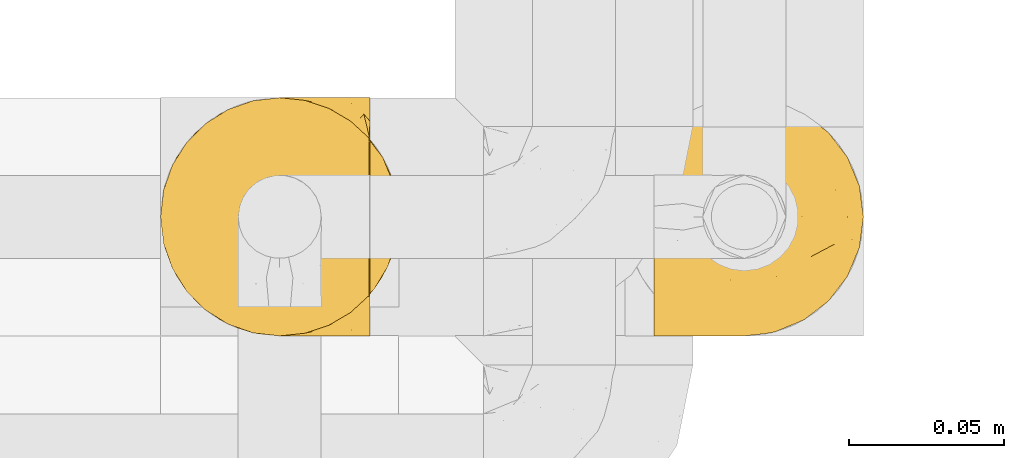
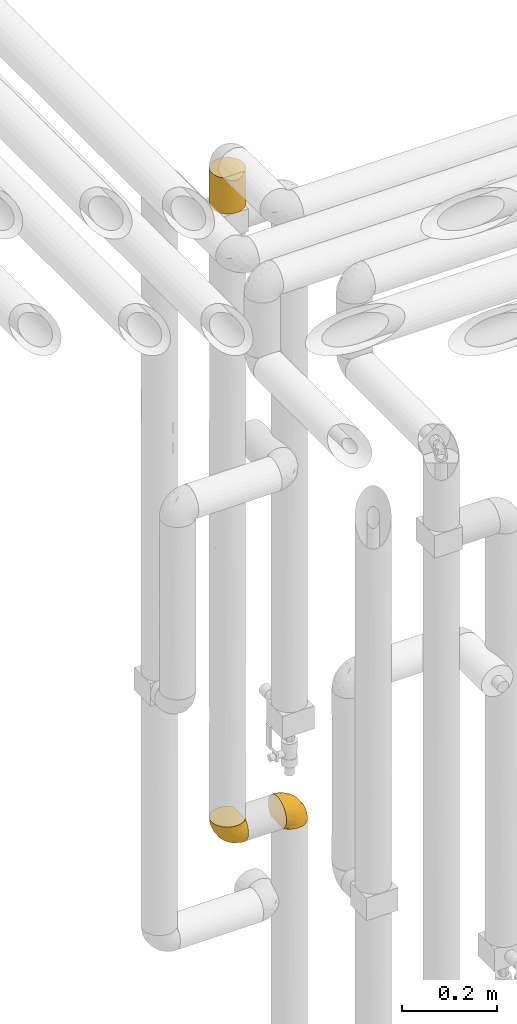
# One storey, part 292 of 827: 3 coverings.
"""IFC2X3 building model written with IfcOpenShell, lengths in millimetres."""

import ifcopenshell
import ifcopenshell.guid

model = None  # the IFC model being written
_history = None  # IfcOwnerHistory: only IFC2X3 demands one
_inside = {}  # id of a spatial element -> (the spatial element, [elements in it])
_under = {}  # id of a project, library or spatial element -> (it, [spatial elements below it])
_declared = {}  # id of a project -> (the project, [libraries it declares])
_typed = {}  # id of a type object -> (the type object, [elements of that type])
_made_of = {}  # id of a material, layer set ... -> (it, [elements and type objects made of it])


def new_model(schema):
    """Start an empty IFC model of exactly this schema.

    Asked for "IFC4X3", IfcOpenShell would pick the latest addendum, in which some entities
    have other attributes; the version numbers below select the first issue.
    IFC2X3 requires an IfcOwnerHistory on every rooted entity: one is made here for all.
    """
    global model, _history
    if schema == "IFC4X3":
        model = ifcopenshell.file(schema_version=(4, 3, 0, 0))
    else:
        model = ifcopenshell.file(schema=schema)
    _inside.clear()
    _under.clear()
    _declared.clear()
    _typed.clear()
    _made_of.clear()
    _history = None
    if model.schema == "IFC2X3":
        org = make("IfcOrganization", Name="unknown")
        user = make(
            "IfcPersonAndOrganization",
            ThePerson=make("IfcPerson", FamilyName="unknown"),
            TheOrganization=org,
        )
        app = make(
            "IfcApplication",
            ApplicationDeveloper=org,
            Version="unknown",
            ApplicationFullName="unknown",
            ApplicationIdentifier="unknown",
        )
        _history = make(
            "IfcOwnerHistory",
            OwningUser=user,
            OwningApplication=app,
            ChangeAction="ADDED",
            CreationDate=0,
        )
    return model


def make(cls, **values):
    """One entity of the class cls with the attributes given. An attribute that is None is left unset."""
    return model.create_entity(
        cls, **{name: value for name, value in values.items() if value is not None}
    )


def entity(cls, *values):
    """Any entity or typed value of the class cls, its attributes in the order of the schema. None: left unset."""
    e = model.create_entity(cls)
    for i, value in enumerate(values):
        if value is not None:
            e[i] = value
    return e


def rooted(cls, **values):
    """An entity with a GlobalId (a new one), such as an element, a storey or a relation."""
    return make(cls, GlobalId=ifcopenshell.guid.new(), OwnerHistory=_history, **values)


def si_unit(unit_type, name, prefix=None):
    """IfcSIUnit, for example si_unit("LENGTHUNIT", "METRE", prefix="MILLI")."""
    return make("IfcSIUnit", UnitType=unit_type, Prefix=prefix, Name=name)


def converted_unit(unit_type, name, factor, base, dimensions=None, offset=None):
    """IfcConversionBasedUnit, such as the inch: factor (a typed value) times the base unit."""
    return make(
        "IfcConversionBasedUnit"
        if offset is None
        else "IfcConversionBasedUnitWithOffset",
        ConversionOffset=offset,
        Dimensions=None
        if dimensions is None
        else entity("IfcDimensionalExponents", *dimensions),
        UnitType=unit_type,
        Name=name,
        ConversionFactor=make(
            "IfcMeasureWithUnit", ValueComponent=factor, UnitComponent=base
        ),
    )


def derived_unit(unit_type, elements):
    """IfcDerivedUnit: a product of units, each with its exponent."""
    return make(
        "IfcDerivedUnit",
        Elements=[
            make("IfcDerivedUnitElement", Unit=unit, Exponent=power)
            for unit, power in elements
        ],
        UnitType=unit_type,
    )


def assignment(units):
    """IfcUnitAssignment: the units of a project."""
    return None if units is None else make("IfcUnitAssignment", Units=units)


def point(xyz):
    """IfcCartesianPoint."""
    return None if xyz is None else make("IfcCartesianPoint", Coordinates=xyz)


def direction(xyz):
    """IfcDirection."""
    return None if xyz is None else make("IfcDirection", DirectionRatios=xyz)


def frame(location, z_axis=None, x_axis=None):
    """IfcAxis2Placement3D, a coordinate frame: its origin and axes. An axis left out is left unset."""
    return make(
        "IfcAxis2Placement3D",
        Location=point(location),
        Axis=direction(z_axis),
        RefDirection=direction(x_axis),
    )


def origin():
    """The frame at (0, 0, 0) with its axes left unset."""
    return frame((0.0, 0.0, 0.0))


def place(relative_to, where):
    """IfcLocalPlacement: puts the frame where relative to a parent placement (None: the world)."""
    return make(
        "IfcLocalPlacement", PlacementRelTo=relative_to, RelativePlacement=where
    )


def context(
    kind, dimensions, precision=None, world=None, true_north=None, identifier=None
):
    """IfcGeometricRepresentationContext, for example the 3D "Model" context."""
    return make(
        "IfcGeometricRepresentationContext",
        ContextIdentifier=identifier,
        ContextType=kind,
        CoordinateSpaceDimension=dimensions,
        Precision=precision,
        WorldCoordinateSystem=world,
        TrueNorth=true_north,
    )


def subcontext(parent, identifier, kind, view, scale=None):
    """IfcGeometricRepresentationSubContext, for example "Body" below "Model"."""
    return make(
        "IfcGeometricRepresentationSubContext",
        ContextIdentifier=identifier,
        ContextType=kind,
        ParentContext=parent,
        TargetScale=scale,
        TargetView=view,
    )


def project(units=None, contexts=None):
    """IfcProject with its units and contexts."""
    return rooted(
        "IfcProject",
        Name="project",
        RepresentationContexts=contexts,
        UnitsInContext=assignment(units),
    )


def spatial(cls, under=None, at=None, **own):
    """A site, building, storey or space (cls), placed at a placement, below another one or the project."""
    s = rooted(cls, ObjectPlacement=at, **own)
    if under is not None:
        _under.setdefault(under.id(), (under, []))[1].append(s)
    return s


def faces_of(points, faces, orient=None, outer=None):
    """IfcFace entities. A face is a list of loops; a loop is a list of indices into points, from 0.

    orient and outer hold one flag for each loop. By default every Orientation is true, the
    first loop of a face is its IfcFaceOuterBound and the others are IfcFaceBound.
    """
    made = []
    for i, loops in enumerate(faces):
        bounds = []
        for j, loop in enumerate(loops):
            is_outer = j == 0 if outer is None else outer[i][j]
            bounds.append(
                make(
                    "IfcFaceOuterBound" if is_outer else "IfcFaceBound",
                    Bound=make("IfcPolyLoop", Polygon=[points[k] for k in loop]),
                    Orientation=True if orient is None else orient[i][j],
                )
            )
        made.append(make("IfcFace", Bounds=bounds))
    return made


def faceted_brep(points, faces, orient=None, outer=None, voids=None):
    """IfcFacetedBrep: a solid bounded by flat faces; with voids (closed shells), ...WithVoids."""
    shared = [point(p) for p in points]
    hull = make("IfcClosedShell", CfsFaces=faces_of(shared, faces, orient, outer))
    if voids is None:
        return make("IfcFacetedBrep", Outer=hull)
    return make(
        "IfcFacetedBrepWithVoids",
        Outer=hull,
        Voids=[
            make(cls, CfsFaces=faces_of(shared, fs, o, b)) for cls, fs, o, b in voids
        ],
    )


def shape(context_of_items, identifier, shape_type, items):
    """IfcShapeRepresentation: the items that make up one representation, for example the "Body"."""
    return make(
        "IfcShapeRepresentation",
        ContextOfItems=context_of_items,
        RepresentationIdentifier=identifier,
        RepresentationType=shape_type,
        Items=items,
    )


def made_of(thing, what):
    """Note that an element or type object is made of a material, layer set ...; save() writes the relation."""
    if what is not None:
        _made_of.setdefault(what.id(), (what, []))[1].append(thing)
    return thing


def element(
    cls,
    number,
    at=None,
    inside=None,
    cuts=None,
    type_object=None,
    material=None,
    context=None,
    identifier="Body",
    shape_type=None,
    held_by="IfcProductDefinitionShape",
    body=None,
    shapes=None,
    **own,
):
    """One element of the class cls, such as IfcWall. Its Tag is "e" and its number.

    at: its placement. inside: the storey or other place that contains it. cuts: it is an
    opening in that element (IfcRelVoidsElement). A single representation is given by context,
    identifier, shape_type and body (its items); several are given by shapes. held_by: the class
    of the entity that holds the representations. save() writes the other relations.
    """
    e = rooted(cls, Tag="e%d" % number, ObjectPlacement=at, **own)
    if body is not None:
        shapes = [shape(context, identifier, shape_type, body)]
    if shapes is not None:
        e.Representation = make(held_by, Representations=shapes)
    if inside is not None:
        _inside.setdefault(inside.id(), (inside, []))[1].append(e)
    if cuts is not None:
        rooted(
            "IfcRelVoidsElement", RelatingBuildingElement=cuts, RelatedOpeningElement=e
        )
    if type_object is not None:
        _typed.setdefault(type_object.id(), (type_object, []))[1].append(e)
    return made_of(e, material)


def aggregate(whole, parts):
    """IfcRelAggregates: a whole, such as a stair, and the parts it consists of."""
    return rooted("IfcRelAggregates", RelatingObject=whole, RelatedObjects=parts)


def save(model, path):
    """Write the relations noted so far, then the file.

    IfcRelAggregates (storeys below a building ...), IfcRelContainedInSpatialStructure (elements
    in a storey), IfcRelDefinesByType, IfcRelAssociatesMaterial and IfcRelDeclares: one each for
    every whole, place, type object, material and project.
    """
    for whole, parts in _under.values():
        aggregate(whole, parts)
    for where, things in _inside.values():
        rooted(
            "IfcRelContainedInSpatialStructure",
            RelatedElements=things,
            RelatingStructure=where,
        )
    for kind, things in _typed.values():
        rooted("IfcRelDefinesByType", RelatedObjects=things, RelatingType=kind)
    for what, things in _made_of.values():
        rooted("IfcRelAssociatesMaterial", RelatedObjects=things, RelatingMaterial=what)
    for by, libraries in _declared.values():
        rooted("IfcRelDeclares", RelatingContext=by, RelatedDefinitions=libraries)
    model.write(path)


model = new_model("IFC2X3")

# Units and contexts
model_context = context("Model", 3, precision=0.01, world=origin(), true_north=direction((6.12303176911189e-17, 1.0)))
body_context = subcontext(model_context, "Body", "Model", "MODEL_VIEW")
ifc_project = project(units=[si_unit("LENGTHUNIT", "METRE", prefix="MILLI"), si_unit("AREAUNIT", "SQUARE_METRE"), si_unit("VOLUMEUNIT", "CUBIC_METRE"), converted_unit("PLANEANGLEUNIT", "DEGREE", entity("IfcRatioMeasure", 0.0174532925199433), si_unit("PLANEANGLEUNIT", "RADIAN"), dimensions=[0, 0, 0, 0, 0, 0, 0]), si_unit("MASSUNIT", "GRAM", prefix="KILO"), derived_unit("MASSDENSITYUNIT", [(si_unit("MASSUNIT", "GRAM", prefix="KILO"), 1), (si_unit("LENGTHUNIT", "METRE"), -3)]), derived_unit("MOMENTOFINERTIAUNIT", [(si_unit("LENGTHUNIT", "METRE"), 4)]), si_unit("TIMEUNIT", "SECOND"), si_unit("FREQUENCYUNIT", "HERTZ"), si_unit("THERMODYNAMICTEMPERATUREUNIT", "DEGREE_CELSIUS"), derived_unit("THERMALTRANSMITTANCEUNIT", [(si_unit("MASSUNIT", "GRAM", prefix="KILO"), 1), (si_unit("THERMODYNAMICTEMPERATUREUNIT", "KELVIN"), -1), (si_unit("TIMEUNIT", "SECOND"), -3)]), derived_unit("VOLUMETRICFLOWRATEUNIT", [(si_unit("LENGTHUNIT", "METRE"), 3), (si_unit("TIMEUNIT", "SECOND"), -1)]), derived_unit("MASSFLOWRATEUNIT", [(si_unit("MASSUNIT", "GRAM", prefix="KILO"), 1), (si_unit("TIMEUNIT", "SECOND"), -1)]), derived_unit("ROTATIONALFREQUENCYUNIT", [(si_unit("TIMEUNIT", "SECOND"), -1)]), si_unit("ELECTRICCURRENTUNIT", "AMPERE"), si_unit("ELECTRICVOLTAGEUNIT", "VOLT"), si_unit("POWERUNIT", "WATT"), si_unit("FORCEUNIT", "NEWTON", prefix="KILO"), si_unit("ILLUMINANCEUNIT", "LUX"), si_unit("LUMINOUSFLUXUNIT", "LUMEN"), si_unit("LUMINOUSINTENSITYUNIT", "CANDELA"), derived_unit("USERDEFINED", [(si_unit("MASSUNIT", "GRAM", prefix="KILO"), -1), (si_unit("LENGTHUNIT", "METRE"), -2), (si_unit("TIMEUNIT", "SECOND"), 3), (si_unit("LUMINOUSFLUXUNIT", "LUMEN"), 1)]), derived_unit("LINEARVELOCITYUNIT", [(si_unit("LENGTHUNIT", "METRE"), 1), (si_unit("TIMEUNIT", "SECOND"), -1)]), si_unit("PRESSUREUNIT", "PASCAL"), derived_unit("USERDEFINED", [(si_unit("LENGTHUNIT", "METRE"), -2), (si_unit("MASSUNIT", "GRAM", prefix="KILO"), 1), (si_unit("TIMEUNIT", "SECOND"), -2)]), derived_unit("LINEARFORCEUNIT", [(si_unit("MASSUNIT", "GRAM", prefix="KILO"), 1), (si_unit("LENGTHUNIT", "METRE"), 1), (si_unit("TIMEUNIT", "SECOND"), -2), (si_unit("LENGTHUNIT", "METRE"), -1)]), derived_unit("PLANARFORCEUNIT", [(si_unit("MASSUNIT", "GRAM", prefix="KILO"), 1), (si_unit("LENGTHUNIT", "METRE"), 1), (si_unit("TIMEUNIT", "SECOND"), -2), (si_unit("LENGTHUNIT", "METRE"), -2)])], contexts=[model_context])

# Site, building, storey
site_placement = place(None, origin())
site = spatial("IfcSite", under=ifc_project, at=site_placement, CompositionType="ELEMENT")
building_placement = place(site_placement, origin())
building = spatial("IfcBuilding", under=site, at=building_placement, CompositionType="ELEMENT")
storey_placement = place(building_placement, frame((0.0, 0.0, 28200.0)))
storey = spatial("IfcBuildingStorey", under=building, at=storey_placement, Name="08", CompositionType="ELEMENT", Elevation=28200.0)

# Coverings
covering_1_placement = place(storey_placement, frame((35112.19, 15782.0, 1249.3)))
element("IfcCovering", 1, at=covering_1_placement, inside=storey, Name=":ADSK_", ObjectType=":ADSK_", PredefinedType="INSULATION", context=body_context, shape_type="Brep", body=[
    faceted_brep([(1.6, 5.41, 47.38), (1.6, 9.99, 54.67), (1.6, 16.08, 60.76), (1.6, 23.37, 65.34), (1.6, 31.49, 68.18), (1.6, 40.05, 69.15), (1.6, 48.61, 68.18), (1.6, 56.73, 65.33), (1.6, 64.02, 60.75), (1.6, 70.11, 54.66), (1.6, 74.69, 47.37), (1.6, 77.53, 39.25), (1.6, 78.5, 30.7), (1.6, 77.63, 22.59), (1.6, 75.08, 14.86), (1.6, 70.97, 7.84), (1.6, 65.47, 1.85), (1.6, 63.27, 1.85), (1.6, 61.53, 1.85), (1.6, 59.57, 1.85), (1.6, 57.6, 1.85), (1.6, 55.63, 1.85), (1.6, 53.67, 1.85), (1.6, 51.7, 1.85), (1.6, 49.73, 1.85), (1.6, 47.54, 1.85), (1.6, 45.34, 1.85), (1.6, 43.15, 1.85), (1.6, 40.96, 1.85), (1.6, 38.76, 1.85), (1.6, 36.57, 1.85), (1.6, 34.37, 1.85), (1.6, 32.18, 1.85), (1.6, 29.98, 1.85), (1.6, 27.79, 1.85), (1.6, 25.6, 1.85), (1.6, 23.4, 1.85), (1.6, 21.21, 1.85), (1.6, 19.01, 1.85), (1.6, 16.82, 1.85), (1.6, 14.62, 1.85), (1.6, 9.12, 7.85), (1.6, 5.0, 14.88), (1.6, 2.46, 22.61), (1.6, 1.6, 30.7), (1.6, 2.56, 39.26), (1.85, 65.47, 1.6), (7.85, 70.97, 1.6), (14.87, 75.09, 1.6), (22.6, 77.63, 1.6), (30.7, 78.5, 1.6), (40.65, 77.19, 1.6), (49.92, 73.34, 1.6), (57.88, 67.23, 1.6), (63.99, 59.27, 1.6), (67.84, 50.0, 1.6), (69.15, 40.05, 1.6), (67.84, 30.09, 1.6), (63.99, 20.82, 1.6), (57.88, 12.86, 1.6), (49.92, 6.75, 1.6), (40.65, 2.91, 1.6), (30.7, 1.6, 1.6), (22.6, 2.46, 1.6), (14.87, 5.0, 1.6), (7.85, 9.12, 1.6), (1.85, 14.62, 1.6), (1.85, 16.82, 1.6), (1.85, 17.8, 1.6), (1.85, 19.39, 1.6), (1.85, 20.98, 1.6), (1.85, 22.57, 1.6), (1.85, 24.16, 1.6), (1.85, 25.75, 1.6), (1.85, 27.33, 1.6), (1.85, 28.92, 1.6), (1.85, 30.51, 1.6), (1.85, 32.1, 1.6), (1.85, 33.69, 1.6), (1.85, 35.28, 1.6), (1.85, 36.87, 1.6), (1.85, 38.46, 1.6), (1.85, 40.05, 1.6), (1.85, 41.63, 1.6), (1.85, 43.22, 1.6), (1.85, 44.81, 1.6), (1.85, 46.4, 1.6), (1.85, 47.99, 1.6), (1.85, 49.58, 1.6), (1.85, 51.17, 1.6), (1.85, 52.76, 1.6), (1.85, 54.72, 1.6), (1.85, 56.69, 1.6), (1.85, 58.88, 1.6), (1.85, 61.08, 1.6), (1.85, 63.27, 1.6), (1.77, 37.77, 1.78), (1.78, 36.07, 1.77), (1.77, 32.96, 1.78), (1.77, 31.36, 1.77), (1.76, 56.52, 1.79), (1.77, 54.96, 1.78), (1.79, 18.75, 1.76), (1.78, 58.07, 1.77), (1.78, 50.37, 1.77), (1.78, 23.36, 1.76), (1.78, 24.95, 1.77), (1.78, 42.43, 1.77), (1.74, 15.97, 1.8), (1.78, 51.96, 1.76), (1.78, 53.47, 1.77), (1.77, 48.63, 1.78), (1.78, 63.93, 1.77), (1.78, 40.93, 1.77), (1.78, 29.72, 1.76), (1.77, 62.4, 1.77), (1.77, 60.92, 1.78), (1.77, 17.31, 1.77), (1.78, 21.74, 1.77), (1.78, 34.56, 1.77), (1.77, 20.18, 1.78), (1.77, 14.62, 1.77), (1.72, 14.62, 1.8), (1.66, 14.62, 1.82), (1.77, 65.47, 1.77), (1.8, 65.47, 1.72), (1.82, 65.47, 1.66), (1.79, 59.5, 1.76), (1.78, 47.1, 1.77), (1.79, 45.61, 1.76), (1.78, 28.18, 1.77), (1.82, 14.62, 1.66), (1.8, 14.62, 1.72), (1.76, 26.61, 1.78), (1.66, 65.47, 1.82), (1.72, 65.47, 1.8), (1.78, 39.32, 1.77), (1.77, 44.12, 1.78), (9.41, 72.26, 3.72), (17.65, 76.57, 7.41), (7.41, 71.77, 6.13), (21.47, 78.5, 21.47), (15.21, 77.9, 19.34), (16.15, 78.5, 26.8), (28.75, 78.5, 8.87), (13.67, 75.52, 9.2), (12.79, 76.13, 12.79), (19.18, 77.81, 14.62), (29.16, 78.5, 7.34), (9.04, 72.4, 5.33), (7.41, 76.56, 17.64), (5.74, 71.77, 7.7), (3.72, 72.25, 9.41), (8.87, 78.5, 28.75), (26.8, 78.5, 16.15), (9.53, 75.75, 14.14), (7.34, 78.5, 29.16), (37.63, 50.46, 57.02), (17.92, 52.75, 64.92), (27.45, 40.05, 64.0), (37.01, 77.7, 11.92), (34.22, 77.66, 19.16), (45.87, 71.02, 28.65), (56.57, 63.45, 24.62), (52.31, 70.55, 15.19), (42.07, 75.57, 18.36), (44.74, 75.57, 9.2), (21.49, 72.61, 46.98), (11.02, 72.61, 50.24), (15.64, 67.24, 56.1), (26.02, 77.74, 28.97), (36.59, 57.43, 54.46), (65.49, 47.19, 21.34), (63.99, 54.76, 18.4), (15.2, 40.05, 66.44), (60.27, 63.45, 12.07), (45.25, 60.1, 45.49), (35.21, 63.72, 50.57), (22.52, 76.83, 36.04), (12.03, 76.34, 42.07), (13.32, 60.51, 62.12), (35.9, 72.59, 37.37), (33.87, 76.05, 29.39), (25.73, 66.15, 53.59), (26.34, 60.51, 58.06), (46.78, 51.88, 49.27), (59.54, 55.34, 29.63), (60.18, 48.67, 33.21), (53.93, 53.89, 40.1), (53.36, 46.73, 44.08), (49.36, 40.05, 49.36), (38.4, 40.05, 56.68), (66.44, 40.05, 15.2), (50.09, 63.95, 35.57), (41.08, 67.24, 41.7), (31.14, 69.62, 46.4), (28.19, 73.6, 41.41), (64.0, 40.05, 27.45), (56.68, 40.05, 38.4), (43.9, 4.52, 12.99), (65.46, 32.72, 21.33), (52.22, 27.18, 42.89), (37.61, 29.63, 57.04), (15.64, 12.86, 56.11), (13.31, 19.59, 62.13), (50.02, 9.54, 21.89), (59.28, 16.64, 16.62), (53.05, 17.48, 32.9), (21.48, 7.49, 46.99), (11.01, 7.49, 50.25), (12.03, 3.75, 42.08), (41.02, 20.75, 49.91), (35.39, 2.33, 15.6), (26.8, 1.6, 16.15), (28.75, 1.6, 8.87), (7.34, 1.6, 29.16), (65.81, 26.94, 13.16), (53.28, 9.54, 10.83), (59.8, 31.21, 33.8), (61.82, 25.33, 25.02), (17.91, 27.35, 64.92), (41.4, 8.17, 32.83), (40.48, 4.3, 20.56), (26.34, 19.59, 58.07), (31.68, 2.23, 21.46), (27.68, 2.45, 28.1), (16.15, 1.6, 26.8), (21.47, 1.6, 21.47), (28.05, 12.86, 51.29), (22.54, 3.27, 36.04), (8.87, 1.6, 28.75), (37.3, 2.29, 8.45), (41.07, 12.86, 41.73), (32.24, 6.89, 39.27), (47.4, 12.43, 33.56), (35.77, 4.1, 27.29), (17.65, 3.53, 7.41), (11.06, 6.88, 3.51), (8.55, 8.16, 4.68), (6.63, 9.02, 5.52), (12.77, 5.0, 8.75), (12.79, 3.96, 12.79), (7.41, 3.52, 17.65), (18.97, 2.4, 13.9), (3.72, 7.83, 9.42), (5.76, 8.32, 7.68), (15.21, 2.19, 19.33), (9.52, 4.34, 14.13)], [[[0, 1, 2, 3, 4, 5, 6, 7, 8, 9, 10, 11, 12, 13, 14, 15, 16, 17, 18, 19, 20, 21, 22, 23, 24, 25, 26, 27, 28, 29, 30, 31, 32, 33, 34, 35, 36, 37, 38, 39, 40, 41, 42, 43, 44, 45]], [[46, 47, 48, 49, 50, 51, 52, 53, 54, 55, 56, 57, 58, 59, 60, 61, 62, 63, 64, 65, 66, 67, 68, 69, 70, 71, 72, 73, 74, 75, 76, 77, 78, 79, 80, 81, 82, 83, 84, 85, 86, 87, 88, 89, 90, 91, 92, 93, 94, 95]], [[96, 97, 30]], [[98, 77, 99]], [[100, 101, 21]], [[69, 68, 102]], [[20, 19, 103]], [[24, 23, 104]], [[20, 103, 100]], [[72, 105, 106]], [[84, 83, 107]], [[89, 88, 104]], [[108, 67, 66]], [[109, 110, 90]], [[111, 25, 24]], [[112, 17, 16]], [[82, 113, 83]], [[109, 23, 22]], [[114, 76, 75]], [[105, 36, 106]], [[104, 111, 24]], [[18, 115, 116]], [[97, 96, 80]], [[67, 108, 117]], [[105, 71, 118]], [[31, 97, 119]], [[102, 120, 69]], [[108, 121, 122, 123, 40]], [[112, 95, 115]], [[17, 115, 18]], [[94, 116, 115]], [[117, 68, 67]], [[38, 117, 39]], [[112, 124, 125, 126, 46]], [[17, 112, 115]], [[70, 120, 118]], [[39, 117, 108]], [[120, 38, 37]], [[120, 37, 118]], [[120, 70, 69]], [[116, 94, 127]], [[128, 86, 129]], [[117, 38, 102]], [[74, 130, 75]], [[99, 33, 32]], [[115, 95, 94]], [[39, 108, 40]], [[108, 66, 131, 132, 121]], [[105, 72, 71]], [[118, 37, 36]], [[71, 70, 118]], [[35, 106, 36]], [[36, 105, 118]], [[35, 133, 106]], [[74, 73, 133]], [[106, 133, 73]], [[99, 114, 33]], [[133, 35, 34]], [[73, 72, 106]], [[95, 112, 46]], [[112, 16, 134, 135, 124]], [[130, 114, 75]], [[99, 76, 114]], [[114, 130, 33]], [[34, 33, 130]], [[78, 77, 98]], [[98, 119, 78]], [[130, 133, 34]], [[133, 130, 74]], [[79, 97, 80]], [[98, 99, 32]], [[98, 32, 31]], [[77, 76, 99]], [[97, 79, 119]], [[136, 96, 29]], [[30, 97, 31]], [[136, 29, 28]], [[81, 80, 96]], [[29, 96, 30]], [[31, 119, 98]], [[119, 79, 78]], [[96, 136, 81]], [[82, 81, 136]], [[113, 107, 83]], [[84, 107, 137]], [[107, 27, 137]], [[113, 28, 107]], [[27, 107, 28]], [[85, 84, 137]], [[137, 27, 26]], [[113, 136, 28]], [[136, 113, 82]], [[109, 89, 104]], [[86, 85, 129]], [[89, 109, 90]], [[111, 87, 128]], [[26, 129, 137]], [[88, 111, 104]], [[25, 111, 128]], [[22, 110, 109]], [[23, 109, 104]], [[110, 91, 90]], [[100, 92, 101]], [[110, 22, 101]], [[91, 110, 101]], [[116, 19, 18]], [[111, 88, 87]], [[127, 103, 19]], [[25, 128, 26]], [[86, 128, 87]], [[128, 129, 26]], [[137, 129, 85]], [[120, 102, 38]], [[117, 102, 68]], [[91, 101, 92]], [[21, 101, 22]], [[93, 92, 103]], [[100, 21, 20]], [[100, 103, 92]], [[127, 93, 103]], [[93, 127, 94]], [[116, 127, 19]], [[126, 138, 47]], [[48, 138, 139]], [[140, 125, 124]], [[141, 142, 143]], [[144, 49, 139]], [[145, 140, 146]], [[48, 139, 49]], [[139, 145, 147]], [[49, 144, 148, 50]], [[126, 125, 149]], [[14, 13, 150]], [[151, 146, 140]], [[149, 140, 145]], [[152, 151, 135]], [[152, 14, 150]], [[16, 15, 134]], [[13, 153, 150]], [[124, 151, 140]], [[141, 147, 142]], [[14, 152, 15]], [[15, 152, 134]], [[47, 46, 126]], [[139, 154, 144]], [[138, 48, 47]], [[125, 140, 149]], [[135, 134, 152]], [[146, 155, 142]], [[145, 146, 147]], [[149, 139, 138]], [[147, 141, 154]], [[147, 146, 142]], [[139, 147, 154]], [[139, 149, 145]], [[149, 138, 126]], [[155, 146, 151]], [[150, 143, 142]], [[152, 155, 151]], [[150, 142, 155]], [[13, 12, 156, 153]], [[153, 143, 150]], [[152, 150, 155]], [[151, 124, 135]], [[157, 158, 159]], [[160, 154, 161]], [[162, 163, 164]], [[165, 166, 160]], [[167, 168, 169]], [[141, 170, 161]], [[156, 12, 11]], [[158, 157, 171]], [[172, 55, 173]], [[158, 6, 174]], [[175, 54, 53]], [[52, 166, 164]], [[52, 164, 53]], [[54, 175, 173]], [[166, 52, 51]], [[176, 177, 171]], [[178, 143, 179]], [[156, 11, 179]], [[8, 7, 180]], [[169, 9, 8]], [[179, 143, 153, 156]], [[179, 11, 10]], [[168, 179, 10]], [[181, 162, 182]], [[179, 167, 178]], [[183, 184, 177]], [[183, 169, 184]], [[176, 171, 185]], [[172, 186, 187]], [[158, 7, 6]], [[159, 158, 174]], [[184, 180, 158]], [[54, 173, 55]], [[180, 169, 8]], [[188, 189, 187]], [[9, 168, 10]], [[186, 188, 187]], [[190, 157, 159, 191]], [[55, 172, 192]], [[176, 193, 194]], [[161, 170, 182]], [[162, 164, 165]], [[175, 164, 163]], [[51, 50, 148]], [[167, 195, 196]], [[178, 182, 170]], [[6, 5, 174]], [[158, 180, 7]], [[169, 180, 184]], [[169, 168, 9]], [[179, 168, 167]], [[182, 162, 165]], [[162, 194, 193]], [[161, 165, 160]], [[195, 181, 196]], [[192, 172, 197]], [[192, 56, 55]], [[189, 190, 198]], [[198, 197, 187]], [[172, 187, 197]], [[185, 189, 188]], [[198, 187, 189]], [[186, 172, 173]], [[173, 163, 186]], [[193, 186, 163]], [[176, 185, 188]], [[185, 157, 190]], [[188, 186, 193]], [[177, 176, 194]], [[188, 193, 176]], [[162, 193, 163]], [[195, 177, 194]], [[171, 177, 184]], [[181, 195, 194]], [[183, 167, 169]], [[162, 181, 194]], [[196, 182, 178]], [[158, 171, 184]], [[171, 157, 185]], [[177, 195, 183]], [[167, 183, 195]], [[182, 196, 181]], [[178, 170, 143]], [[178, 167, 196]], [[164, 175, 53]], [[173, 175, 163]], [[160, 51, 148]], [[164, 166, 165]], [[51, 160, 166]], [[160, 148, 144, 154]], [[141, 161, 154]], [[182, 165, 161]], [[190, 189, 185]], [[143, 170, 141]], [[60, 199, 61]], [[197, 200, 192]], [[201, 190, 202]], [[200, 57, 192]], [[203, 204, 2]], [[205, 206, 207]], [[208, 209, 210]], [[211, 207, 201]], [[212, 213, 214]], [[45, 215, 210]], [[216, 206, 58]], [[45, 44, 215]], [[59, 217, 60]], [[60, 217, 199]], [[0, 45, 210]], [[218, 201, 219]], [[202, 159, 220]], [[205, 221, 222]], [[223, 204, 203]], [[1, 203, 2]], [[57, 200, 216]], [[220, 3, 204]], [[220, 174, 4]], [[1, 0, 209]], [[212, 224, 213]], [[225, 226, 227]], [[228, 223, 203]], [[208, 210, 229]], [[210, 226, 229]], [[3, 220, 4]], [[58, 206, 59]], [[209, 203, 1]], [[202, 220, 223]], [[228, 203, 208]], [[202, 211, 201]], [[3, 2, 204]], [[202, 190, 191, 159]], [[210, 215, 230, 226]], [[199, 212, 231]], [[232, 233, 221]], [[233, 208, 229]], [[207, 206, 219]], [[217, 206, 205]], [[227, 224, 225]], [[233, 232, 228]], [[201, 207, 219]], [[234, 232, 221]], [[218, 219, 200]], [[202, 223, 211]], [[174, 220, 159]], [[174, 5, 4]], [[61, 231, 62]], [[220, 204, 223]], [[210, 209, 0]], [[203, 209, 208]], [[225, 233, 229]], [[224, 227, 213]], [[221, 233, 235]], [[57, 56, 192]], [[198, 218, 197]], [[200, 219, 216]], [[201, 198, 190]], [[197, 218, 200]], [[198, 201, 218]], [[206, 216, 219]], [[58, 57, 216]], [[231, 212, 214]], [[222, 212, 199]], [[228, 211, 223]], [[207, 211, 232]], [[62, 231, 214]], [[199, 231, 61]], [[233, 228, 208]], [[211, 228, 232]], [[222, 221, 235]], [[234, 205, 207]], [[206, 217, 59]], [[199, 217, 205]], [[205, 222, 199]], [[224, 222, 235]], [[222, 224, 212]], [[224, 235, 225]], [[233, 225, 235]], [[226, 225, 229]], [[205, 234, 221]], [[207, 232, 234]], [[63, 214, 236]], [[214, 213, 236]], [[214, 63, 62]], [[237, 236, 238]], [[238, 132, 131]], [[236, 237, 64]], [[239, 240, 241]], [[63, 236, 64]], [[131, 66, 65]], [[237, 131, 65]], [[242, 230, 43]], [[237, 65, 64]], [[239, 121, 132]], [[42, 242, 43]], [[241, 240, 243]], [[41, 123, 244]], [[43, 230, 215, 44]], [[244, 122, 245]], [[227, 246, 243]], [[241, 247, 245]], [[121, 239, 245]], [[41, 40, 123]], [[132, 238, 239]], [[244, 42, 41]], [[131, 237, 238]], [[240, 239, 238]], [[245, 239, 241]], [[247, 241, 246]], [[247, 244, 245]], [[238, 236, 240]], [[243, 236, 213]], [[236, 243, 240]], [[227, 226, 246]], [[243, 213, 227]], [[242, 246, 226]], [[243, 246, 241]], [[246, 242, 247]], [[244, 247, 242]], [[242, 226, 230]], [[42, 244, 242]], [[122, 244, 123]], [[122, 121, 245]]]),
])
covering_2_placement = place(storey_placement, frame((34952.89, 15782.05, 2877.4)))
element("IfcCovering", 2, at=covering_2_placement, inside=storey, Name=":ADSK_", ObjectType=":ADSK_", PredefinedType="INSULATION", context=body_context, shape_type="Brep", body=[
    faceted_brep([(6.74, 20.8, 1.6), (2.9, 30.06, 1.6), (1.6, 40.0, 1.6), (2.9, 49.93, 1.6), (6.74, 59.2, 1.6), (12.84, 67.15, 1.6), (20.8, 73.25, 1.6), (30.06, 77.09, 1.6), (40.0, 78.4, 1.6), (48.16, 77.52, 1.6), (55.94, 74.93, 1.6), (62.99, 70.75, 1.6), (69.0, 65.17, 1.6), (69.0, 14.82, 1.6), (62.99, 9.24, 1.6), (55.94, 5.06, 1.6), (48.16, 2.47, 1.6), (40.0, 1.6, 1.6), (30.06, 2.9, 1.6), (20.8, 6.74, 1.6), (12.84, 12.84, 1.6), (1.6, 40.0, 93.5), (2.48, 31.79, 93.5), (5.09, 23.98, 93.5), (9.31, 16.91, 93.5), (14.94, 10.9, 93.5), (65.05, 10.9, 93.5), (70.68, 16.91, 93.5), (74.9, 23.98, 93.5), (77.51, 31.79, 93.5), (78.4, 40.0, 93.5), (77.09, 49.93, 93.5), (73.25, 59.2, 93.5), (67.15, 67.15, 93.5), (59.2, 73.25, 93.5), (49.93, 77.09, 93.5), (40.0, 78.4, 93.5), (30.06, 77.09, 93.5), (20.8, 73.25, 93.5), (12.84, 67.15, 93.5), (6.74, 59.2, 93.5), (2.9, 49.93, 93.5), (77.78, 33.17, 10.38), (73.01, 20.38, 5.61), (75.97, 26.56, 8.57), (78.4, 40.0, 11.0), (59.51, 6.92, 89.52), (53.36, 4.0, 86.6), (46.78, 2.2, 84.8), (40.0, 1.6, 84.2), (33.21, 2.2, 84.8), (26.63, 4.0, 86.6), (20.48, 6.92, 89.52), (75.97, 53.43, 8.57), (77.78, 46.82, 10.38), (73.01, 59.61, 5.61)], [[[0, 1, 2, 3, 4, 5, 6, 7, 8, 9, 10, 11, 12, 13, 14, 15, 16, 17, 18, 19, 20]], [[21, 22, 23, 24, 25, 26, 27, 28, 29, 30, 31, 32, 33, 34, 35, 36, 37, 38, 39, 40, 41]], [[30, 29, 42]], [[28, 27, 43]], [[29, 28, 44]], [[42, 45, 30]], [[43, 44, 28]], [[13, 43, 27]], [[42, 29, 44]], [[27, 26, 13]], [[26, 46, 14]], [[47, 48, 16]], [[46, 47, 15]], [[14, 46, 15]], [[48, 17, 16]], [[16, 15, 47]], [[17, 48, 49]], [[26, 14, 13]], [[50, 51, 18]], [[52, 25, 19]], [[51, 52, 19]], [[49, 50, 17]], [[17, 50, 18]], [[51, 19, 18]], [[25, 20, 19]], [[0, 24, 23]], [[1, 23, 22]], [[2, 22, 21]], [[20, 24, 0]], [[0, 23, 1]], [[22, 2, 1]], [[24, 20, 25]], [[3, 2, 21, 41]], [[4, 3, 41, 40]], [[40, 39, 5, 4]], [[7, 6, 38, 37]], [[8, 7, 37, 36]], [[39, 38, 6, 5]], [[9, 36, 35]], [[10, 35, 34]], [[11, 34, 33]], [[8, 36, 9]], [[9, 35, 10]], [[34, 11, 10]], [[33, 12, 11]], [[53, 32, 31]], [[31, 30, 54]], [[45, 54, 30]], [[55, 12, 32]], [[54, 53, 31]], [[55, 32, 53]], [[32, 12, 33]], [[12, 55, 53, 54, 45, 42, 44, 43, 13]], [[52, 51, 50, 49, 48, 47, 46, 26, 25]]]),
])
covering_3_placement = place(storey_placement, frame((34952.84, 15782.0, 1239.95)))
element("IfcCovering", 3, at=covering_3_placement, inside=storey, Name=":ADSK_", ObjectType=":ADSK_", PredefinedType="INSULATION", context=body_context, shape_type="Brep", body=[
    faceted_brep([(23.36, 74.68, 69.15), (16.07, 70.1, 69.15), (9.98, 64.01, 69.15), (5.4, 56.72, 69.15), (2.56, 48.6, 69.15), (1.6, 40.05, 69.15), (2.56, 31.49, 69.15), (5.41, 23.36, 69.15), (9.99, 16.07, 69.15), (16.08, 9.98, 69.15), (23.37, 5.4, 69.15), (31.49, 2.56, 69.15), (40.05, 1.6, 69.15), (48.15, 2.46, 69.15), (55.88, 5.01, 69.15), (62.9, 9.13, 69.15), (68.89, 14.62, 69.15), (68.89, 16.82, 69.15), (68.89, 18.56, 69.15), (68.89, 20.52, 69.15), (68.89, 22.49, 69.15), (68.89, 24.46, 69.15), (68.89, 26.42, 69.15), (68.89, 28.39, 69.15), (68.89, 30.36, 69.15), (68.89, 32.55, 69.15), (68.89, 34.75, 69.15), (68.89, 36.94, 69.15), (68.89, 39.13, 69.15), (68.89, 41.33, 69.15), (68.89, 43.52, 69.15), (68.89, 45.72, 69.15), (68.89, 47.91, 69.15), (68.89, 50.11, 69.15), (68.89, 52.3, 69.15), (68.89, 54.49, 69.15), (68.89, 56.69, 69.15), (68.89, 58.88, 69.15), (68.89, 61.08, 69.15), (68.89, 63.27, 69.15), (68.89, 65.47, 69.15), (62.89, 70.97, 69.15), (55.86, 75.09, 69.15), (48.13, 77.64, 69.15), (40.05, 78.5, 69.15), (31.49, 77.53, 69.15), (69.15, 14.62, 68.89), (69.15, 9.12, 62.89), (69.15, 5.0, 55.87), (69.15, 2.46, 48.14), (69.15, 1.6, 40.05), (69.15, 2.91, 30.09), (69.15, 6.75, 20.82), (69.15, 12.86, 12.86), (69.15, 20.82, 6.75), (69.15, 30.09, 2.91), (69.15, 40.05, 1.6), (69.15, 50.0, 2.91), (69.15, 59.27, 6.75), (69.15, 67.23, 12.86), (69.15, 73.34, 20.82), (69.15, 77.19, 30.09), (69.15, 78.5, 40.05), (69.15, 77.63, 48.14), (69.15, 75.09, 55.87), (69.15, 70.97, 62.89), (69.15, 65.47, 68.89), (69.15, 63.27, 68.89), (69.15, 62.29, 68.89), (69.15, 60.7, 68.89), (69.15, 59.11, 68.89), (69.15, 57.52, 68.89), (69.15, 55.93, 68.89), (69.15, 54.34, 68.89), (69.15, 52.76, 68.89), (69.15, 51.17, 68.89), (69.15, 49.58, 68.89), (69.15, 47.99, 68.89), (69.15, 46.4, 68.89), (69.15, 44.81, 68.89), (69.15, 43.22, 68.89), (69.15, 41.63, 68.89), (69.15, 40.05, 68.89), (69.15, 38.46, 68.89), (69.15, 36.87, 68.89), (69.15, 35.28, 68.89), (69.15, 33.69, 68.89), (69.15, 32.1, 68.89), (69.15, 30.51, 68.89), (69.15, 28.92, 68.89), (69.15, 27.33, 68.89), (69.15, 25.37, 68.89), (69.15, 23.4, 68.89), (69.15, 21.21, 68.89), (69.15, 19.01, 68.89), (69.15, 16.82, 68.89), (68.96, 42.32, 68.97), (68.97, 44.02, 68.96), (68.97, 47.13, 68.97), (68.97, 48.74, 68.97), (68.95, 23.57, 68.98), (68.96, 25.13, 68.97), (68.98, 61.34, 68.96), (68.97, 22.02, 68.96), (68.97, 29.72, 68.96), (68.98, 56.73, 68.96), (68.97, 55.14, 68.96), (68.97, 37.66, 68.96), (68.94, 64.12, 69.0), (68.98, 28.13, 68.96), (68.98, 26.62, 68.96), (68.96, 31.46, 68.97), (68.97, 16.16, 68.96), (68.98, 39.16, 68.96), (68.98, 50.37, 68.96), (68.97, 17.69, 68.97), (68.96, 19.17, 68.97), (68.97, 62.78, 68.97), (68.97, 58.35, 68.96), (68.98, 45.53, 68.96), (68.96, 59.91, 68.97), (68.97, 65.47, 68.97), (68.94, 65.47, 69.02), (68.92, 65.47, 69.08), (68.97, 14.62, 68.97), (69.02, 14.62, 68.94), (69.08, 14.62, 68.92), (68.98, 20.59, 68.96), (68.97, 32.99, 68.96), (68.98, 34.48, 68.95), (68.97, 51.91, 68.96), (69.08, 65.47, 68.92), (69.02, 65.47, 68.94), (68.96, 53.48, 68.98), (68.92, 14.62, 69.08), (68.94, 14.62, 69.02), (68.97, 40.77, 68.96), (68.96, 35.97, 68.97), (67.02, 7.84, 61.33), (63.33, 3.53, 53.1), (64.61, 8.32, 63.33), (49.27, 1.6, 49.27), (51.4, 2.19, 55.53), (43.94, 1.6, 54.6), (61.87, 1.6, 41.99), (61.54, 4.57, 57.07), (57.95, 3.96, 57.95), (56.12, 2.28, 51.56), (63.4, 1.6, 41.58), (65.41, 7.69, 61.7), (53.1, 3.53, 63.33), (63.04, 8.32, 65.0), (61.33, 7.84, 67.02), (41.99, 1.6, 61.87), (54.6, 1.6, 43.94), (56.6, 4.34, 61.21), (41.58, 1.6, 63.4), (13.72, 29.63, 33.11), (5.82, 27.34, 52.82), (6.74, 40.05, 43.3), (58.82, 2.39, 33.73), (51.58, 2.43, 36.52), (42.09, 9.07, 24.87), (46.12, 16.64, 14.17), (55.56, 9.54, 18.43), (52.38, 4.52, 28.67), (61.54, 4.52, 26.0), (23.76, 7.49, 49.25), (20.5, 7.49, 59.72), (14.64, 12.85, 55.1), (41.77, 2.35, 44.72), (16.28, 22.66, 34.15), (49.4, 32.9, 5.25), (52.34, 25.33, 6.75), (4.3, 40.05, 55.54), (58.67, 16.64, 10.47), (25.26, 19.99, 25.49), (20.17, 16.37, 35.53), (34.7, 3.26, 48.22), (28.67, 3.75, 58.71), (8.62, 19.58, 57.42), (33.37, 7.5, 34.84), (41.35, 4.04, 36.87), (17.15, 13.94, 45.01), (12.68, 19.58, 44.4), (21.47, 28.21, 23.96), (41.11, 24.75, 11.2), (37.53, 31.42, 10.56), (30.64, 26.2, 16.81), (26.66, 33.36, 17.38), (21.38, 40.05, 21.38), (14.06, 40.05, 32.34), (55.54, 40.05, 4.3), (35.17, 16.14, 20.65), (29.04, 12.85, 29.66), (24.34, 10.47, 39.6), (29.33, 6.49, 42.55), (43.3, 40.05, 6.74), (32.34, 40.05, 14.06), (57.75, 75.57, 26.84), (49.41, 47.37, 5.28), (27.85, 52.91, 18.52), (13.7, 50.46, 33.13), (14.63, 67.23, 55.1), (8.61, 60.5, 57.43), (48.85, 70.55, 20.72), (54.13, 63.45, 11.46), (37.84, 62.61, 17.69), (23.75, 72.6, 49.26), (20.49, 72.6, 59.73), (28.66, 76.34, 58.71), (20.83, 59.34, 29.72), (55.15, 77.76, 35.35), (54.6, 78.5, 43.94), (61.87, 78.5, 41.99), (41.58, 78.5, 63.4), (57.58, 53.16, 4.93), (59.91, 70.55, 17.46), (36.94, 48.88, 10.94), (45.72, 54.76, 8.92), (5.82, 52.74, 52.83), (37.91, 71.93, 29.34), (50.18, 75.79, 30.26), (12.67, 60.5, 44.4), (49.29, 77.86, 39.06), (42.64, 77.64, 43.06), (43.94, 78.5, 54.6), (49.27, 78.5, 49.27), (19.45, 67.23, 42.69), (34.7, 76.82, 48.2), (41.99, 78.5, 61.87), (62.29, 77.8, 33.44), (29.01, 67.23, 29.67), (31.47, 73.2, 38.5), (37.18, 67.66, 23.35), (43.45, 75.99, 34.97), (63.33, 76.57, 53.1), (67.23, 73.21, 59.68), (66.07, 71.93, 62.19), (65.22, 71.07, 64.11), (61.99, 75.09, 57.97), (57.95, 76.13, 57.95), (53.09, 76.57, 63.33), (56.84, 77.69, 51.77), (61.33, 72.26, 67.02), (63.06, 71.77, 64.98), (51.41, 77.9, 55.53), (56.61, 75.75, 61.22)], [[[0, 1, 2, 3, 4, 5, 6, 7, 8, 9, 10, 11, 12, 13, 14, 15, 16, 17, 18, 19, 20, 21, 22, 23, 24, 25, 26, 27, 28, 29, 30, 31, 32, 33, 34, 35, 36, 37, 38, 39, 40, 41, 42, 43, 44, 45]], [[46, 47, 48, 49, 50, 51, 52, 53, 54, 55, 56, 57, 58, 59, 60, 61, 62, 63, 64, 65, 66, 67, 68, 69, 70, 71, 72, 73, 74, 75, 76, 77, 78, 79, 80, 81, 82, 83, 84, 85, 86, 87, 88, 89, 90, 91, 92, 93, 94, 95]], [[96, 97, 30]], [[98, 77, 99]], [[100, 101, 21]], [[69, 68, 102]], [[20, 19, 103]], [[24, 23, 104]], [[20, 103, 100]], [[72, 105, 106]], [[84, 83, 107]], [[89, 88, 104]], [[108, 67, 66]], [[109, 110, 90]], [[111, 25, 24]], [[112, 17, 16]], [[82, 113, 83]], [[109, 23, 22]], [[114, 76, 75]], [[105, 36, 106]], [[104, 111, 24]], [[18, 115, 116]], [[97, 96, 80]], [[67, 108, 117]], [[105, 71, 118]], [[31, 97, 119]], [[102, 120, 69]], [[108, 121, 122, 123, 40]], [[112, 95, 115]], [[17, 115, 18]], [[94, 116, 115]], [[117, 68, 67]], [[38, 117, 39]], [[112, 124, 125, 126, 46]], [[17, 112, 115]], [[70, 120, 118]], [[39, 117, 108]], [[120, 38, 37]], [[120, 37, 118]], [[120, 70, 69]], [[116, 94, 127]], [[128, 86, 129]], [[117, 38, 102]], [[74, 130, 75]], [[99, 33, 32]], [[115, 95, 94]], [[39, 108, 40]], [[108, 66, 131, 132, 121]], [[105, 72, 71]], [[118, 37, 36]], [[71, 70, 118]], [[35, 106, 36]], [[36, 105, 118]], [[35, 133, 106]], [[74, 73, 133]], [[106, 133, 73]], [[99, 114, 33]], [[133, 35, 34]], [[73, 72, 106]], [[95, 112, 46]], [[112, 16, 134, 135, 124]], [[130, 114, 75]], [[99, 76, 114]], [[114, 130, 33]], [[34, 33, 130]], [[78, 77, 98]], [[98, 119, 78]], [[130, 133, 34]], [[133, 130, 74]], [[79, 97, 80]], [[98, 99, 32]], [[98, 32, 31]], [[77, 76, 99]], [[97, 79, 119]], [[136, 96, 29]], [[30, 97, 31]], [[136, 29, 28]], [[81, 80, 96]], [[29, 96, 30]], [[31, 119, 98]], [[119, 79, 78]], [[96, 136, 81]], [[82, 81, 136]], [[113, 107, 83]], [[84, 107, 137]], [[107, 27, 137]], [[113, 28, 107]], [[27, 107, 28]], [[85, 84, 137]], [[137, 27, 26]], [[113, 136, 28]], [[136, 113, 82]], [[109, 89, 104]], [[86, 85, 129]], [[89, 109, 90]], [[111, 87, 128]], [[26, 129, 137]], [[88, 111, 104]], [[25, 111, 128]], [[22, 110, 109]], [[23, 109, 104]], [[110, 91, 90]], [[100, 92, 101]], [[110, 22, 101]], [[91, 110, 101]], [[116, 19, 18]], [[111, 88, 87]], [[127, 103, 19]], [[25, 128, 26]], [[86, 128, 87]], [[128, 129, 26]], [[137, 129, 85]], [[120, 102, 38]], [[117, 102, 68]], [[91, 101, 92]], [[21, 101, 22]], [[93, 92, 103]], [[100, 21, 20]], [[100, 103, 92]], [[127, 93, 103]], [[93, 127, 94]], [[116, 127, 19]], [[126, 138, 47]], [[48, 138, 139]], [[140, 125, 124]], [[141, 142, 143]], [[144, 49, 139]], [[145, 140, 146]], [[48, 139, 49]], [[139, 145, 147]], [[49, 144, 148, 50]], [[126, 125, 149]], [[14, 13, 150]], [[151, 146, 140]], [[149, 140, 145]], [[152, 151, 135]], [[152, 14, 150]], [[16, 15, 134]], [[13, 153, 150]], [[124, 151, 140]], [[141, 147, 142]], [[14, 152, 15]], [[15, 152, 134]], [[47, 46, 126]], [[139, 154, 144]], [[138, 48, 47]], [[125, 140, 149]], [[135, 134, 152]], [[146, 155, 142]], [[145, 146, 147]], [[149, 139, 138]], [[147, 141, 154]], [[147, 146, 142]], [[139, 147, 154]], [[139, 149, 145]], [[149, 138, 126]], [[155, 146, 151]], [[150, 143, 142]], [[152, 155, 151]], [[150, 142, 155]], [[13, 12, 156, 153]], [[153, 143, 150]], [[152, 150, 155]], [[151, 124, 135]], [[157, 158, 159]], [[160, 154, 161]], [[162, 163, 164]], [[165, 166, 160]], [[167, 168, 169]], [[141, 170, 161]], [[156, 12, 11]], [[158, 157, 171]], [[172, 55, 173]], [[158, 6, 174]], [[175, 54, 53]], [[52, 166, 164]], [[52, 164, 53]], [[54, 175, 173]], [[166, 52, 51]], [[176, 177, 171]], [[178, 143, 179]], [[156, 11, 179]], [[8, 7, 180]], [[169, 9, 8]], [[179, 143, 153, 156]], [[179, 11, 10]], [[168, 179, 10]], [[181, 162, 182]], [[179, 167, 178]], [[183, 184, 177]], [[183, 169, 184]], [[176, 171, 185]], [[172, 186, 187]], [[158, 7, 6]], [[159, 158, 174]], [[184, 180, 158]], [[54, 173, 55]], [[180, 169, 8]], [[188, 189, 187]], [[9, 168, 10]], [[186, 188, 187]], [[190, 157, 159, 191]], [[55, 172, 192]], [[176, 193, 194]], [[161, 170, 182]], [[162, 164, 165]], [[175, 164, 163]], [[51, 50, 148]], [[167, 195, 196]], [[178, 182, 170]], [[6, 5, 174]], [[158, 180, 7]], [[169, 180, 184]], [[169, 168, 9]], [[179, 168, 167]], [[182, 162, 165]], [[162, 194, 193]], [[161, 165, 160]], [[195, 181, 196]], [[192, 172, 197]], [[192, 56, 55]], [[189, 190, 198]], [[198, 197, 187]], [[172, 187, 197]], [[185, 189, 188]], [[198, 187, 189]], [[186, 172, 173]], [[173, 163, 186]], [[193, 186, 163]], [[176, 185, 188]], [[185, 157, 190]], [[188, 186, 193]], [[177, 176, 194]], [[188, 193, 176]], [[162, 193, 163]], [[195, 177, 194]], [[171, 177, 184]], [[181, 195, 194]], [[183, 167, 169]], [[162, 181, 194]], [[196, 182, 178]], [[158, 171, 184]], [[171, 157, 185]], [[177, 195, 183]], [[167, 183, 195]], [[182, 196, 181]], [[178, 170, 143]], [[178, 167, 196]], [[164, 175, 53]], [[173, 175, 163]], [[160, 51, 148]], [[164, 166, 165]], [[51, 160, 166]], [[160, 148, 144, 154]], [[141, 161, 154]], [[182, 165, 161]], [[190, 189, 185]], [[143, 170, 141]], [[60, 199, 61]], [[197, 200, 192]], [[201, 190, 202]], [[200, 57, 192]], [[203, 204, 2]], [[205, 206, 207]], [[208, 209, 210]], [[211, 207, 201]], [[212, 213, 214]], [[45, 215, 210]], [[216, 206, 58]], [[45, 44, 215]], [[59, 217, 60]], [[60, 217, 199]], [[0, 45, 210]], [[218, 201, 219]], [[202, 159, 220]], [[205, 221, 222]], [[223, 204, 203]], [[1, 203, 2]], [[57, 200, 216]], [[220, 3, 204]], [[220, 174, 4]], [[1, 0, 209]], [[212, 224, 213]], [[225, 226, 227]], [[228, 223, 203]], [[208, 210, 229]], [[210, 226, 229]], [[3, 220, 4]], [[58, 206, 59]], [[209, 203, 1]], [[202, 220, 223]], [[228, 203, 208]], [[202, 211, 201]], [[3, 2, 204]], [[202, 190, 191, 159]], [[210, 215, 230, 226]], [[199, 212, 231]], [[232, 233, 221]], [[233, 208, 229]], [[207, 206, 219]], [[217, 206, 205]], [[227, 224, 225]], [[233, 232, 228]], [[201, 207, 219]], [[234, 232, 221]], [[218, 219, 200]], [[202, 223, 211]], [[174, 220, 159]], [[174, 5, 4]], [[61, 231, 62]], [[220, 204, 223]], [[210, 209, 0]], [[203, 209, 208]], [[225, 233, 229]], [[224, 227, 213]], [[221, 233, 235]], [[57, 56, 192]], [[198, 218, 197]], [[200, 219, 216]], [[201, 198, 190]], [[197, 218, 200]], [[198, 201, 218]], [[206, 216, 219]], [[58, 57, 216]], [[231, 212, 214]], [[222, 212, 199]], [[228, 211, 223]], [[207, 211, 232]], [[62, 231, 214]], [[199, 231, 61]], [[233, 228, 208]], [[211, 228, 232]], [[222, 221, 235]], [[234, 205, 207]], [[206, 217, 59]], [[199, 217, 205]], [[205, 222, 199]], [[224, 222, 235]], [[222, 224, 212]], [[224, 235, 225]], [[233, 225, 235]], [[226, 225, 229]], [[205, 234, 221]], [[207, 232, 234]], [[63, 214, 236]], [[214, 213, 236]], [[214, 63, 62]], [[237, 236, 238]], [[238, 132, 131]], [[236, 237, 64]], [[239, 240, 241]], [[63, 236, 64]], [[131, 66, 65]], [[237, 131, 65]], [[242, 230, 43]], [[237, 65, 64]], [[239, 121, 132]], [[42, 242, 43]], [[241, 240, 243]], [[41, 123, 244]], [[43, 230, 215, 44]], [[244, 122, 245]], [[227, 246, 243]], [[241, 247, 245]], [[121, 239, 245]], [[41, 40, 123]], [[132, 238, 239]], [[244, 42, 41]], [[131, 237, 238]], [[240, 239, 238]], [[245, 239, 241]], [[247, 241, 246]], [[247, 244, 245]], [[238, 236, 240]], [[243, 236, 213]], [[236, 243, 240]], [[227, 226, 246]], [[243, 213, 227]], [[242, 246, 226]], [[243, 246, 241]], [[246, 242, 247]], [[244, 247, 242]], [[242, 226, 230]], [[42, 244, 242]], [[122, 244, 123]], [[122, 121, 245]]]),
])

save(model, "model.ifc")
